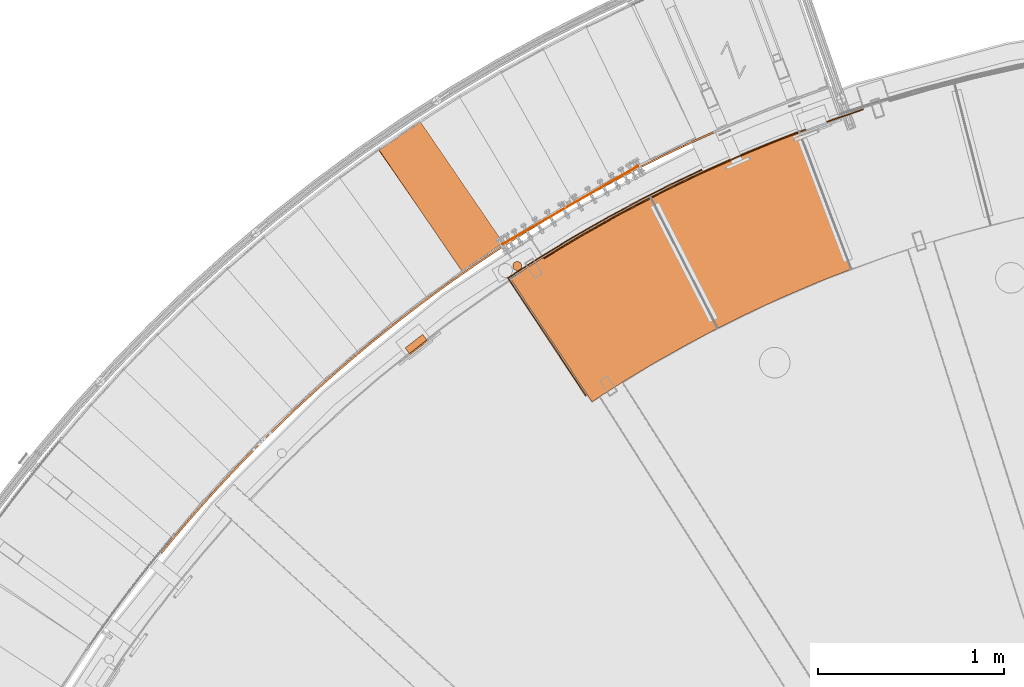
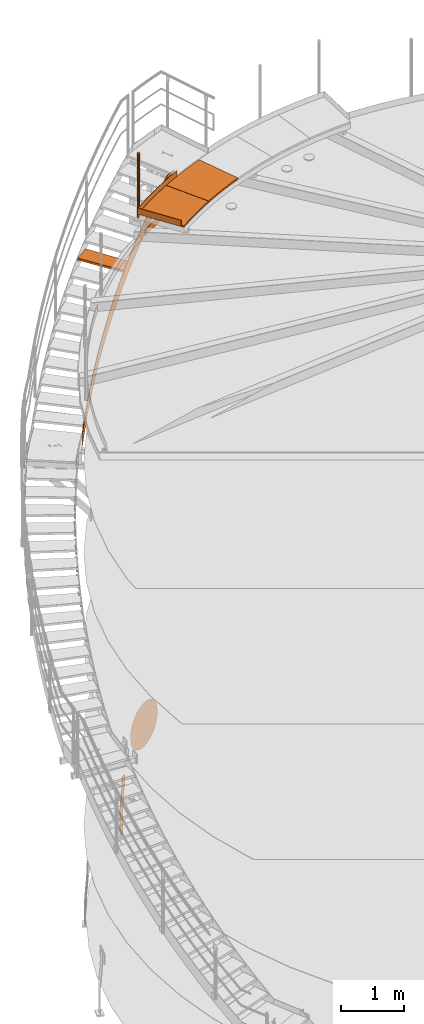
# One storey, part 36 of 126: 10 proxies.
"""IFC2X3 building model written with IfcOpenShell, lengths in millimetres."""

from ifc_helpers import new_model, si_unit, origin, origin_with_axes, place, context, project, spatial, faceted_brep, material, element, save


model = new_model("IFC2X3")

# Units and contexts
context_of_model_1 = context(None, 3, precision=0.1, world=origin())
context_of_model_2 = context(None, 3, precision=0.1, world=origin())
ifc_project = project(units=[si_unit("LENGTHUNIT", "METRE", prefix="MILLI"), si_unit("AREAUNIT", "SQUARE_METRE", prefix="CENTI"), si_unit("VOLUMEUNIT", "CUBIC_METRE", prefix="CENTI"), si_unit("MASSUNIT", "GRAM", prefix="KILO")], contexts=[context_of_model_1, context_of_model_2])

# Site, building, storey
site_placement = place(None, origin_with_axes())
site = spatial("IfcSite", under=ifc_project, at=site_placement, CompositionType="ELEMENT")
building_placement = place(site_placement, origin_with_axes())
building = spatial("IfcBuilding", under=site, at=building_placement, CompositionType="ELEMENT")
storey_placement = place(building_placement, origin_with_axes())
storey = spatial("IfcBuildingStorey", under=building, at=storey_placement, CompositionType="ELEMENT")

# Proxies
ifc_material_1 = material(Name="STAHL")
proxy_1_placement = place(storey_placement, origin_with_axes())
element("IfcBuildingElementProxy", 1, at=proxy_1_placement, inside=storey, material=ifc_material_1, Name="profile", context=context_of_model_2, shape_type="Brep", body=[
    faceted_brep([(3653.7, 14739.6, 896.0), (3655.8, 14740.8, 852.6), (3661.8, 14744.3, 809.8), (3671.9, 14750.1, 768.0), (3685.8, 14758.2, 727.6), (3703.4, 14768.3, 689.3), (3724.5, 14780.5, 653.3), (3748.9, 14794.6, 620.2), (3776.2, 14810.3, 590.4), (3774.7, 14812.9, 590.4), (3747.4, 14797.2, 620.2), (3723.0, 14783.1, 653.3), (3701.9, 14770.9, 689.3), (3684.3, 14760.8, 727.6), (3670.4, 14752.7, 768.0), (3660.3, 14746.9, 809.8), (3654.3, 14743.4, 852.6), (3652.2, 14742.2, 896.0), (3654.3, 14743.4, 939.4), (3660.3, 14746.9, 982.2), (3670.4, 14752.7, 1024.0), (3684.3, 14760.8, 1064.4), (3701.9, 14770.9, 1102.7), (3723.0, 14783.1, 1138.7), (3747.4, 14797.2, 1171.8), (3774.7, 14812.9, 1201.6), (3804.6, 14830.2, 1227.9), (3836.8, 14848.8, 1250.3), (3871.0, 14868.5, 1268.5), (3906.6, 14889.1, 1282.4), (3943.3, 14910.3, 1291.7), (3980.7, 14931.9, 1296.4), (4018.3, 14953.6, 1296.4), (4055.7, 14975.2, 1291.7), (4092.4, 14996.4, 1282.4), (4128.0, 15016.9, 1268.5), (4162.2, 15036.6, 1250.3), (4194.4, 15055.2, 1227.9), (4224.3, 15072.5, 1201.6), (4251.6, 15088.3, 1171.8), (4276.0, 15102.3, 1138.7), (4297.1, 15114.5, 1102.7), (4314.7, 15124.7, 1064.4), (4328.6, 15132.7, 1024.0), (4338.7, 15138.5, 982.2), (4344.7, 15142.1, 939.4), (4346.8, 15143.2, 896.0), (4344.7, 15142.1, 852.6), (4338.7, 15138.5, 809.8), (4328.6, 15132.7, 768.0), (4314.7, 15124.7, 727.6), (4297.1, 15114.5, 689.3), (4276.0, 15102.3, 653.3), (4251.6, 15088.3, 620.2), (4224.3, 15072.5, 590.4), (4194.4, 15055.2, 564.1), (4162.2, 15036.6, 541.7), (4128.0, 15016.9, 523.5), (4092.4, 14996.4, 509.6), (4055.7, 14975.2, 500.3), (4018.3, 14953.6, 495.6), (3980.7, 14931.9, 495.6), (3943.3, 14910.3, 500.3), (3906.6, 14889.1, 509.6), (3871.0, 14868.5, 523.5), (3836.8, 14848.8, 541.7), (3804.6, 14830.2, 564.1), (3806.1, 14827.6, 564.1), (3838.3, 14846.2, 541.7), (3872.5, 14865.9, 523.5), (3908.1, 14886.5, 509.6), (3944.8, 14907.7, 500.3), (3982.2, 14929.3, 495.6), (4019.8, 14951.0, 495.6), (4057.2, 14972.6, 500.3), (4093.9, 14993.8, 509.6), (4129.5, 15014.3, 523.5), (4163.7, 15034.0, 541.7), (4195.9, 15052.6, 564.1), (4225.8, 15069.9, 590.4), (4253.1, 15085.7, 620.2), (4277.5, 15099.7, 653.3), (4298.6, 15111.9, 689.3), (4316.2, 15122.1, 727.6), (4330.1, 15130.1, 768.0), (4340.2, 15135.9, 809.8), (4346.2, 15139.5, 852.6), (4348.3, 15140.6, 896.0), (4346.2, 15139.5, 939.4), (4340.2, 15135.9, 982.2), (4330.1, 15130.1, 1024.0), (4316.2, 15122.1, 1064.4), (4298.6, 15111.9, 1102.7), (4277.5, 15099.7, 1138.7), (4253.1, 15085.7, 1171.8), (4225.8, 15069.9, 1201.6), (4195.9, 15052.6, 1227.9), (4163.7, 15034.0, 1250.3), (4129.5, 15014.3, 1268.5), (4093.9, 14993.8, 1282.4), (4057.2, 14972.6, 1291.7), (4019.8, 14951.0, 1296.4), (3982.2, 14929.3, 1296.4), (3944.8, 14907.7, 1291.7), (3908.1, 14886.5, 1282.4), (3872.5, 14865.9, 1268.5), (3838.3, 14846.2, 1250.3), (3806.1, 14827.6, 1227.9), (3776.2, 14810.3, 1201.6), (3748.9, 14794.6, 1171.8), (3724.5, 14780.5, 1138.7), (3703.4, 14768.3, 1102.7), (3685.8, 14758.2, 1064.4), (3671.9, 14750.1, 1024.0), (3661.8, 14744.3, 982.2), (3655.8, 14740.8, 939.4), (3636.4, 14729.6, 896.0), (3638.4, 14730.8, 940.0), (3644.4, 14734.2, 983.5), (3654.2, 14739.9, 1026.1), (3667.9, 14747.8, 1067.2), (3685.2, 14757.8, 1106.5), (3706.0, 14769.8, 1143.5), (3730.1, 14783.7, 1177.7), (3757.0, 14799.3, 1208.9), (3786.7, 14816.4, 1236.6), (3818.7, 14834.9, 1260.6), (3852.7, 14854.5, 1280.6), (3888.3, 14875.1, 1296.4), (3925.2, 14896.4, 1307.8), (3962.9, 14918.1, 1314.7), (4001.0, 14940.1, 1317.0), (4039.1, 14962.1, 1314.7), (4076.8, 14983.9, 1307.8), (4113.7, 15005.2, 1296.4), (4149.3, 15025.7, 1280.6), (4183.3, 15045.4, 1260.6), (4213.8, 15066.5, 1236.6), (4181.8, 15048.0, 1260.6), (4147.8, 15028.3, 1280.6), (4112.2, 15007.8, 1296.4), (4075.3, 14986.5, 1307.8), (4037.6, 14964.7, 1314.7), (3999.5, 14942.7, 1317.0), (3961.4, 14920.7, 1314.7), (3923.7, 14899.0, 1307.8), (3886.8, 14877.7, 1296.4), (3851.2, 14857.1, 1280.6), (3817.2, 14837.5, 1260.6), (3785.2, 14819.0, 1236.6), (3755.5, 14801.9, 1208.9), (3728.6, 14786.3, 1177.7), (3704.5, 14772.4, 1143.5), (3683.7, 14760.4, 1106.5), (3666.4, 14750.4, 1067.2), (3652.7, 14742.5, 1026.1), (3642.9, 14736.8, 983.5), (3636.9, 14733.4, 940.0), (3634.9, 14732.2, 896.0), (3636.9, 14733.4, 852.0), (3642.9, 14736.8, 808.5), (3652.7, 14742.5, 765.9), (3666.4, 14750.4, 724.8), (3683.7, 14760.4, 685.5), (3704.5, 14772.4, 648.5), (3728.6, 14786.3, 614.3), (3755.5, 14801.9, 583.1), (3785.2, 14819.0, 555.4), (3817.2, 14837.5, 531.4), (3851.2, 14857.1, 511.4), (3886.8, 14877.7, 495.6), (3923.7, 14899.0, 484.2), (3961.4, 14920.7, 477.3), (3999.5, 14942.7, 475.0), (4037.6, 14964.7, 477.3), (4075.3, 14986.5, 484.2), (4112.2, 15007.8, 495.6), (4147.8, 15028.3, 511.4), (4181.8, 15048.0, 531.4), (4213.8, 15066.5, 555.4), (4243.5, 15083.6, 583.1), (4270.4, 15099.2, 614.3), (4294.5, 15113.0, 648.5), (4315.2, 15125.0, 685.5), (4332.6, 15135.0, 724.8), (4346.3, 15142.9, 765.9), (4356.1, 15148.6, 808.5), (4362.1, 15152.1, 852.0), (4364.1, 15153.2, 896.0), (4362.1, 15152.1, 940.0), (4356.1, 15148.6, 983.5), (4346.3, 15142.9, 1026.1), (4332.6, 15135.0, 1067.2), (4315.2, 15125.0, 1106.5), (4294.5, 15113.0, 1143.5), (4270.4, 15099.2, 1177.7), (4243.5, 15083.6, 1208.9), (4215.3, 15063.9, 1236.6), (4245.0, 15081.0, 1208.9), (4271.9, 15096.6, 1177.7), (4296.0, 15110.4, 1143.5), (4316.7, 15122.4, 1106.5), (4334.1, 15132.4, 1067.2), (4347.8, 15140.3, 1026.1), (4357.6, 15146.0, 983.5), (4363.6, 15149.5, 940.0), (4365.6, 15150.6, 896.0), (4363.6, 15149.5, 852.0), (4357.6, 15146.0, 808.5), (4347.8, 15140.3, 765.9), (4334.1, 15132.4, 724.8), (4316.7, 15122.4, 685.5), (4296.0, 15110.4, 648.5), (4271.9, 15096.6, 614.3), (4245.0, 15081.0, 583.1), (4215.3, 15063.9, 555.4), (4183.3, 15045.4, 531.4), (4149.3, 15025.7, 511.4), (4113.7, 15005.2, 495.6), (4076.8, 14983.9, 484.2), (4039.1, 14962.1, 477.3), (4001.0, 14940.1, 475.0), (3962.9, 14918.1, 477.3), (3925.2, 14896.4, 484.2), (3888.3, 14875.1, 495.6), (3852.7, 14854.5, 511.4), (3818.7, 14834.9, 531.4), (3786.7, 14816.4, 555.4), (3757.0, 14799.3, 583.1), (3730.1, 14783.7, 614.3), (3706.0, 14769.8, 648.5), (3685.2, 14757.8, 685.5), (3667.9, 14747.8, 724.8), (3654.2, 14739.9, 765.9), (3644.4, 14734.2, 808.5), (3638.4, 14730.8, 852.0)], [[[0, 1, 2, 3, 4, 5, 6, 7, 8, 9, 10, 11, 12, 13, 14, 15, 16, 17, 18, 19, 20, 21, 22, 23, 24, 25, 26, 27, 28, 29, 30, 31, 32, 33, 34, 35, 36, 37, 38, 39, 40, 41, 42, 43, 44, 45, 46, 47, 48, 49, 50, 51, 52, 53, 54, 55, 56, 57, 58, 59, 60, 61, 62, 63, 64, 65, 66, 9, 8, 67, 68, 69, 70, 71, 72, 73, 74, 75, 76, 77, 78, 79, 80, 81, 82, 83, 84, 85, 86, 87, 88, 89, 90, 91, 92, 93, 94, 95, 96, 97, 98, 99, 100, 101, 102, 103, 104, 105, 106, 107, 108, 109, 110, 111, 112, 113, 114, 115]], [[116, 117, 118, 119, 120, 121, 122, 123, 124, 125, 126, 127, 128, 129, 130, 131, 132, 133, 134, 135, 136, 137, 138, 139, 140, 141, 142, 143, 144, 145, 146, 147, 148, 149, 150, 151, 152, 153, 154, 155, 156, 157, 158, 159, 160, 161, 162, 163, 164, 165, 166, 167, 168, 169, 170, 171, 172, 173, 174, 175, 176, 177, 178, 179, 180, 181, 182, 183, 184, 185, 186, 187, 188, 189, 190, 191, 192, 193, 194, 195, 196, 137, 136, 197, 198, 199, 200, 201, 202, 203, 204, 205, 206, 207, 208, 209, 210, 211, 212, 213, 214, 215, 216, 217, 218, 219, 220, 221, 222, 223, 224, 225, 226, 227, 228, 229, 230, 231, 232, 233, 234, 235]], [[158, 157, 156, 155, 154, 153, 152, 151, 150, 149, 148, 147, 146, 145, 144, 143, 142, 141, 140, 139, 138, 137, 196, 195, 194, 193, 192, 191, 190, 189, 188, 187, 186, 185, 184, 183, 182, 181, 180, 53, 52, 51, 50, 49, 48, 47, 46, 45, 44, 43, 42, 41, 40, 39, 38, 37, 36, 35, 34, 33, 32, 31, 30, 29, 28, 27, 26, 25, 24, 23, 22, 21, 20, 19, 18, 17, 16, 15, 14, 13, 12, 11, 10, 9, 66, 65, 64, 63, 62, 61, 60, 59, 58, 57, 56, 55, 54, 53, 180, 179, 178, 177, 176, 175, 174, 173, 172, 171, 170, 169, 168, 167, 166, 165, 164, 163, 162, 161, 160, 159]], [[116, 235, 234, 233, 232, 231, 230, 229, 228, 227, 226, 225, 224, 223, 222, 221, 220, 219, 218, 217, 216, 215, 214, 213, 80, 79, 78, 77, 76, 75, 74, 73, 72, 71, 70, 69, 68, 67, 8, 7, 6, 5, 4, 3, 2, 1, 0, 115, 114, 113, 112, 111, 110, 109, 108, 107, 106, 105, 104, 103, 102, 101, 100, 99, 98, 97, 96, 95, 94, 93, 92, 91, 90, 89, 88, 87, 86, 85, 84, 83, 82, 81, 80, 213, 212, 211, 210, 209, 208, 207, 206, 205, 204, 203, 202, 201, 200, 199, 198, 197, 136, 135, 134, 133, 132, 131, 130, 129, 128, 127, 126, 125, 124, 123, 122, 121, 120, 119, 118, 117]]]),
])
proxy_2_placement = place(storey_placement, origin_with_axes())
element("IfcBuildingElementProxy", 2, at=proxy_2_placement, inside=storey, material=ifc_material_1, Name="profile", context=context_of_model_2, shape_type="Brep", body=[
    faceted_brep([(3224.1, 14212.2, 654.1), (3229.0, 14205.9, 654.1), (3231.0, 14207.5, 651.1), (3226.0, 14213.8, 651.1), (3227.5, 14214.9, 647.7), (3232.4, 14208.6, 647.7), (3228.4, 14215.6, 643.9), (3233.3, 14209.3, 643.9), (3233.6, 14209.5, 640.0), (3233.6, 14209.5, 540.0), (3210.2, 14239.5, 0.0), (3210.2, 14239.5, -500.0), (3205.3, 14245.8, -500.0), (3205.3, 14245.8, 0.0), (3228.7, 14215.8, 540.0), (3228.7, 14215.8, 640.0), (3143.7, 14139.3, 654.1), (3138.8, 14145.6, 654.1), (3136.8, 14144.0, 651.1), (3141.7, 14137.7, 651.1), (3135.3, 14142.9, 647.7), (3140.3, 14136.6, 647.7), (3134.4, 14142.2, 643.9), (3139.4, 14135.9, 643.9), (3139.1, 14135.7, 540.0), (3139.1, 14135.7, 640.0), (3134.1, 14142.0, 640.0), (3134.1, 14142.0, 540.0), (3110.7, 14171.9, 0.0), (3110.7, 14171.9, -500.0), (3115.7, 14165.6, -500.0), (3115.7, 14165.6, 0.0), (3151.8, 14145.6, 659.6), (3154.8, 14148.0, 660.0), (3217.9, 14197.2, 660.0), (3220.9, 14199.6, 659.6), (3216.0, 14205.9, 659.6), (3212.9, 14203.5, 660.0), (3149.9, 14154.3, 660.0), (3146.8, 14151.9, 659.6), (3143.9, 14149.6, 658.5), (3148.8, 14143.3, 658.5), (3141.1, 14147.4, 656.6), (3146.1, 14141.1, 656.6), (3223.9, 14201.9, 658.5), (3219.0, 14208.2, 658.5), (3226.6, 14204.1, 656.6), (3221.7, 14210.4, 656.6)], [[[0, 1, 2, 3]], [[4, 3, 2, 5]], [[6, 4, 5, 7]], [[7, 8, 9, 10, 11, 12, 13, 14, 15, 6]], [[16, 17, 18, 19]], [[19, 18, 20, 21]], [[21, 20, 22, 23]], [[24, 25, 23, 22, 26, 27, 28, 29, 30, 31]], [[32, 33, 34, 35, 36, 37, 38, 39]], [[32, 39, 40, 41]], [[41, 40, 42, 43]], [[16, 43, 42, 17]], [[36, 35, 44, 45]], [[45, 44, 46, 47]], [[0, 47, 46, 1]], [[27, 26, 22, 20, 18, 17, 42, 40, 39, 38, 37, 36, 45, 47, 0, 3, 4, 6, 15, 14, 13, 12, 29, 28]], [[25, 24, 31, 30, 11, 10, 9, 8, 7, 5, 2, 1, 46, 44, 35, 34, 33, 32, 41, 43, 16, 19, 21, 23]], [[30, 29, 12, 11]]]),
])
proxy_3_placement = place(storey_placement, origin_with_axes())
element("IfcBuildingElementProxy", 3, at=proxy_3_placement, inside=storey, material=ifc_material_1, Name="profile", context=context_of_model_2, shape_type="Brep", body=[
    faceted_brep([(3738.8, 14616.2, 12185.2), (3738.8, 14616.2, 10955.2), (3737.5, 14621.9, 10955.2), (3737.5, 14621.9, 12185.2), (3734.8, 14627.1, 10955.2), (3734.8, 14627.1, 12185.2), (3731.1, 14631.5, 10955.2), (3731.1, 14631.5, 12185.2), (3726.3, 14634.9, 10955.2), (3726.3, 14634.9, 12185.2), (3720.9, 14637.0, 10955.2), (3720.9, 14637.0, 12185.2), (3715.1, 14637.8, 10955.2), (3715.1, 14637.8, 12185.2), (3709.3, 14637.2, 10955.2), (3709.3, 14637.2, 12185.2), (3703.9, 14635.2, 10955.2), (3703.9, 14635.2, 12185.2), (3699.0, 14632.0, 10955.2), (3699.0, 14632.0, 12185.2), (3695.1, 14627.7, 10955.2), (3695.1, 14627.7, 12185.2), (3692.3, 14622.6, 10955.2), (3692.3, 14622.6, 12185.2), (3690.8, 14617.0, 10955.2), (3690.8, 14617.0, 12185.2), (3690.7, 14611.2, 12185.2), (3690.7, 14611.2, 10955.2), (3692.0, 14605.5, 10955.2), (3692.0, 14605.5, 12185.2), (3694.7, 14600.3, 12185.2), (3694.7, 14600.3, 10955.2), (3698.4, 14595.9, 12185.2), (3698.4, 14595.9, 10955.2), (3703.2, 14592.5, 12185.2), (3703.2, 14592.5, 10955.2), (3708.6, 14590.3, 12185.2), (3708.6, 14590.3, 10955.2), (3714.4, 14589.5, 12185.2), (3714.4, 14589.5, 10955.2), (3720.2, 14590.1, 12185.2), (3720.2, 14590.1, 10955.2), (3725.6, 14592.1, 12185.2), (3725.6, 14592.1, 10955.2), (3730.5, 14595.4, 12185.2), (3730.5, 14595.4, 10955.2), (3734.4, 14599.7, 12185.2), (3734.4, 14599.7, 10955.2), (3737.2, 14604.8, 12185.2), (3737.2, 14604.8, 10955.2), (3738.7, 14610.4, 12185.2), (3738.7, 14610.4, 10955.2)], [[[0, 1, 2, 3]], [[3, 2, 4, 5]], [[5, 4, 6, 7]], [[7, 6, 8, 9]], [[9, 8, 10, 11]], [[11, 10, 12, 13]], [[13, 12, 14, 15]], [[15, 14, 16, 17]], [[17, 16, 18, 19]], [[19, 18, 20, 21]], [[21, 20, 22, 23]], [[23, 22, 24, 25]], [[26, 25, 24, 27]], [[26, 27, 28, 29]], [[30, 29, 28, 31]], [[32, 30, 31, 33]], [[34, 32, 33, 35]], [[36, 34, 35, 37]], [[38, 36, 37, 39]], [[40, 38, 39, 41]], [[42, 40, 41, 43]], [[44, 42, 43, 45]], [[46, 44, 45, 47]], [[48, 46, 47, 49]], [[50, 48, 49, 51]], [[0, 50, 51, 1]], [[38, 40, 42, 44, 46, 48, 50, 0, 3, 5, 7, 9, 11, 13, 15, 17, 19, 21, 23, 25, 26, 29, 30, 32, 34, 36]], [[39, 37, 35, 33, 31, 28, 27, 24, 22, 20, 18, 16, 14, 12, 10, 8, 6, 4, 2, 1, 51, 49, 47, 45, 43, 41]]]),
])
proxy_4_placement = place(storey_placement, origin_with_axes())
element("IfcBuildingElementProxy", 4, at=proxy_4_placement, inside=storey, material=ifc_material_1, Name="profile", context=context_of_model_2, shape_type="Brep", body=[
    faceted_brep([(3661.2, 14549.6, 11065.2), (3661.2, 14549.6, 11185.2), (3665.4, 14552.4, 11185.2), (3835.8, 14662.2, 11185.2), (4009.0, 14767.6, 11185.2), (4204.6, 14879.4, 11185.2), (4383.3, 14975.2, 11185.2), (4544.9, 15056.8, 11185.2), (4708.3, 15134.7, 11185.2), (4708.3, 15134.7, 11065.2), (4544.9, 15056.8, 11065.2), (4383.3, 14975.2, 11065.2), (4204.6, 14879.4, 11065.2), (4009.0, 14767.6, 11065.2), (3835.8, 14662.2, 11065.2), (3665.4, 14552.4, 11065.2), (3668.1, 14548.2, 11185.2), (3668.1, 14548.2, 11065.2), (3838.5, 14658.0, 11065.2), (4011.7, 14763.4, 11065.2), (4207.2, 14875.1, 11065.2), (4385.8, 14970.9, 11065.2), (4547.2, 15052.4, 11065.2), (4710.4, 15130.2, 11065.2), (4710.4, 15130.2, 11185.2), (4567.4, 15062.3, 11185.2), (4425.8, 14991.6, 11185.2), (4246.6, 14896.8, 11185.2), (4050.5, 14786.2, 11185.2), (3857.6, 14670.0, 11185.2), (3762.4, 14609.8, 11185.2), (4083.0, 13912.4, 11065.2), (4083.0, 13912.4, 11185.2), (4087.1, 13915.2, 11185.2), (4087.1, 13915.2, 11065.2)], [[[0, 1, 2, 3, 4, 5, 6, 7, 8, 9, 10, 11, 12, 13, 14, 15]], [[16, 17, 18, 19, 20, 21, 22, 23, 24, 25, 26, 27, 28, 29, 30]], [[9, 8, 24, 23]], [[1, 0, 31, 32]], [[32, 33, 16, 30, 29, 28, 27, 26, 25, 24, 8, 7, 6, 5, 4, 3, 2, 1]], [[31, 0, 15, 14, 13, 12, 11, 10, 9, 23, 22, 21, 20, 19, 18, 17, 34]], [[16, 33, 34, 17]], [[32, 31, 34, 33]]]),
])
proxy_5_placement = place(storey_placement, origin_with_axes())
element("IfcBuildingElementProxy", 5, at=proxy_5_placement, inside=storey, material=ifc_material_1, Name="profile", context=context_of_model_2, shape_type="Brep", body=[
    faceted_brep([(3856.5, 14657.3, 10516.0), (3856.5, 14657.3, 10636.0), (4060.3, 14780.1, 10636.0), (4267.7, 14896.7, 10636.0), (4478.5, 15007.0, 10636.0), (4692.6, 15110.7, 10636.0), (4909.8, 15208.0, 10636.0), (5129.8, 15298.6, 10636.0), (5352.4, 15382.5, 10636.0), (5577.5, 15459.6, 10636.0), (5577.5, 15459.6, 10516.0), (5352.4, 15382.5, 10516.0), (5129.8, 15298.6, 10516.0), (4909.8, 15208.0, 10516.0), (4692.6, 15110.7, 10516.0), (4478.5, 15007.0, 10516.0), (4267.7, 14896.7, 10516.0), (4060.3, 14780.1, 10516.0), (3859.2, 14653.1, 10636.0), (4062.8, 14775.8, 10636.0), (4270.1, 14892.3, 10636.0), (4480.8, 15002.5, 10636.0), (4694.7, 15106.2, 10636.0), (4911.8, 15203.4, 10636.0), (5131.6, 15293.9, 10636.0), (5354.1, 15377.8, 10636.0), (5579.0, 15454.8, 10636.0), (3859.2, 14653.1, 10516.0), (4062.8, 14775.8, 10516.0), (4270.1, 14892.3, 10516.0), (4480.8, 15002.5, 10516.0), (4694.7, 15106.2, 10516.0), (4911.8, 15203.4, 10516.0), (5131.6, 15293.9, 10516.0), (5354.1, 15377.8, 10516.0), (5579.0, 15454.8, 10516.0)], [[[0, 1, 2, 3, 4, 5, 6, 7, 8, 9, 10, 11, 12, 13, 14, 15, 16, 17]], [[18, 19, 20, 21, 22, 23, 24, 25, 26, 9, 8, 7, 6, 5, 4, 3, 2, 1]], [[18, 27, 28, 29, 30, 31, 32, 33, 34, 35, 26, 25, 24, 23, 22, 21, 20, 19]], [[27, 0, 17, 16, 15, 14, 13, 12, 11, 10, 35, 34, 33, 32, 31, 30, 29, 28]], [[18, 1, 0, 27]], [[26, 35, 10, 9]]]),
])
proxy_6_placement = place(storey_placement, origin_with_axes())
element("IfcBuildingElementProxy", 6, at=proxy_6_placement, inside=storey, material=ifc_material_1, Name="profile", context=context_of_model_2, shape_type="Brep", body=[
    faceted_brep([(4796.6, 14279.2, 11085.2), (4796.6, 14279.2, 11055.2), (4972.1, 14365.9, 11055.2), (5150.0, 14447.7, 11055.2), (5330.0, 14524.6, 11055.2), (5512.2, 14596.4, 11055.2), (5512.2, 14596.4, 11085.2), (5330.0, 14524.6, 11085.2), (5150.0, 14447.7, 11085.2), (4972.1, 14365.9, 11085.2), (4433.9, 14987.8, 11085.2), (4433.9, 14987.8, 11055.2), (4590.1, 15065.5, 11085.2), (4747.9, 15139.7, 11085.2), (4907.4, 15210.4, 11085.2), (5068.4, 15277.5, 11085.2), (5230.8, 15341.0, 11085.2), (5230.8, 15341.0, 11055.2), (5068.4, 15277.5, 11055.2), (4907.4, 15210.4, 11055.2), (4747.9, 15139.7, 11055.2), (4590.1, 15065.5, 11055.2)], [[[0, 1, 2, 3, 4, 5, 6, 7, 8, 9]], [[0, 10, 11, 1]], [[11, 10, 12, 13, 14, 15, 16, 17, 18, 19, 20, 21]], [[16, 6, 5, 17]], [[0, 9, 8, 7, 6, 16, 15, 14, 13, 12, 10]], [[1, 11, 21, 20, 19, 18, 17, 5, 4, 3, 2]]]),
])
proxy_7_placement = place(storey_placement, origin_with_axes())
element("IfcBuildingElementProxy", 7, at=proxy_7_placement, inside=storey, material=ifc_material_1, Name="profile", context=context_of_model_2, shape_type="Brep", body=[
    faceted_brep([(4117.2, 13882.5, 11085.2), (4117.2, 13882.5, 11055.2), (4281.9, 13988.2, 11055.2), (4449.6, 14089.3, 11055.2), (4620.0, 14185.8, 11055.2), (4793.0, 14277.4, 11055.2), (4793.0, 14277.4, 11085.2), (4620.0, 14185.8, 11085.2), (4449.6, 14089.3, 11085.2), (4281.9, 13988.2, 11085.2), (3677.8, 14546.3, 11085.2), (3677.8, 14546.3, 11055.2), (3861.3, 14664.0, 11085.2), (4048.0, 14776.6, 11085.2), (4237.7, 14884.0, 11085.2), (4430.4, 14986.0, 11085.2), (4430.4, 14986.0, 11055.2), (4237.7, 14884.0, 11055.2), (4048.0, 14776.6, 11055.2), (3861.3, 14664.0, 11055.2)], [[[0, 1, 2, 3, 4, 5, 6, 7, 8, 9]], [[0, 10, 11, 1]], [[11, 10, 12, 13, 14, 15, 16, 17, 18, 19]], [[15, 6, 5, 16]], [[0, 9, 8, 7, 6, 15, 14, 13, 12, 10]], [[1, 11, 19, 18, 17, 16, 5, 4, 3, 2]]]),
])
ifc_material_2 = material(Name="HOLZ")
proxy_8_placement = place(storey_placement, origin_with_axes())
element("IfcBuildingElementProxy", 8, at=proxy_8_placement, inside=storey, material=ifc_material_2, context=context_of_model_2, shape_type="Brep", body=[
    faceted_brep([(3205.7057, 15401.368, 10045.963), (3183.6454, 15387.007, 10045.963), (3161.628, 15372.58, 10045.963), (3139.6538, 15358.087, 10045.963), (3117.723, 15343.529, 10045.963), (3095.8357, 15328.906, 10045.963), (3073.9922, 15314.217, 10045.963), (3052.1926, 15299.463, 10045.963), (3030.4372, 15284.644, 10045.963), (3008.7261, 15269.76, 10045.963), (2987.0595, 15254.811, 10045.963), (2965.4377, 15239.798, 10045.963), (3422.6964, 14583.357, 10045.963), (3444.5485, 14598.525, 10045.963), (3466.4508, 14613.62, 10045.963), (3488.4031, 14628.643, 10045.963), (3510.4051, 14643.592, 10045.963), (3532.4566, 14658.469, 10045.963), (3554.5573, 14673.272, 10045.963), (3576.707, 14688.002, 10045.963), (3598.9055, 14702.658, 10045.963), (3621.1525, 14717.24, 10045.963), (3643.4477, 14731.749, 10045.963), (3205.7057, 15401.368, 10005.963), (3643.4477, 14731.749, 10005.963), (3621.1525, 14717.24, 10005.963), (3598.9055, 14702.658, 10005.963), (3576.707, 14688.002, 10005.963), (3554.5573, 14673.272, 10005.963), (3532.4566, 14658.469, 10005.963), (3510.4051, 14643.592, 10005.963), (3488.4031, 14628.643, 10005.963), (3466.4508, 14613.62, 10005.963), (3444.5485, 14598.525, 10005.963), (3422.6964, 14583.357, 10005.963), (2965.4377, 15239.798, 10005.963), (2987.0595, 15254.811, 10005.963), (3008.7261, 15269.76, 10005.963), (3030.4372, 15284.644, 10005.963), (3052.1926, 15299.463, 10005.963), (3073.9922, 15314.217, 10005.963), (3095.8357, 15328.906, 10005.963), (3117.723, 15343.529, 10005.963), (3139.6538, 15358.087, 10005.963), (3161.628, 15372.58, 10005.963), (3183.6454, 15387.007, 10005.963)], [[[0, 1, 2, 3, 4, 5, 6, 7, 8, 9, 10, 11, 12, 13, 14, 15, 16, 17, 18, 19, 20, 21, 22]], [[23, 24, 25, 26, 27, 28, 29, 30, 31, 32, 33, 34, 35, 36, 37, 38, 39, 40, 41, 42, 43, 44, 45]], [[0, 23, 45, 1]], [[1, 45, 44, 2]], [[2, 44, 43, 3]], [[3, 43, 42, 4]], [[4, 42, 41, 5]], [[5, 41, 40, 6]], [[6, 40, 39, 7]], [[7, 39, 38, 8]], [[8, 38, 37, 9]], [[9, 37, 36, 10]], [[10, 36, 35, 11]], [[11, 35, 34, 12]], [[12, 34, 33, 13]], [[13, 33, 32, 14]], [[14, 32, 31, 15]], [[15, 31, 30, 16]], [[16, 30, 29, 17]], [[17, 29, 28, 18]], [[18, 28, 27, 19]], [[19, 27, 26, 20]], [[20, 26, 25, 21]], [[21, 25, 24, 22]], [[22, 24, 23, 0]]]),
])
ifc_material_3 = material(Name="S235JRG2")
proxy_9_placement = place(storey_placement, origin_with_axes())
element("IfcBuildingElementProxy", 9, at=proxy_9_placement, inside=storey, material=ifc_material_3, context=context_of_model_2, shape_type="Brep", body=[
    faceted_brep([(2971.1265, 15237.649, 10005.55), (2971.1265, 15237.649, 10045.55), (3194.0134, 15390.035, 10045.55), (3194.0134, 15390.035, 10005.55), (3416.996, 14585.498, 10005.55), (3639.8829, 14737.884, 10005.55), (3639.8829, 14737.884, 10045.55), (3416.996, 14585.498, 10045.55)], [[[0, 1, 2, 3]], [[4, 5, 6, 7]], [[0, 4, 7, 1]], [[1, 7, 6, 2]], [[2, 6, 5, 3]], [[3, 5, 4, 0]]]),
])
proxy_10_placement = place(storey_placement, origin_with_axes())
element("IfcBuildingElementProxy", 10, at=proxy_10_placement, inside=storey, material=ifc_material_3, context=context_of_model_2, shape_type="Brep", body=[
    faceted_brep([(1801.9537, 13080.672, 8172.7859), (1809.6931, 13074.339, 8172.7017), (1802.471, 13065.417, 8164.2676), (1794.2032, 13071.097, 8163.7395), (1809.6931, 13074.339, 8420.8838), (1802.471, 13065.417, 8412.4466), (1801.9537, 13080.672, 8420.9227), (1794.2032, 13071.097, 8411.8796), (1856.0518, 13146.076, 8235.1084), (1863.7237, 13139.662, 8234.9977), (1863.7237, 13139.662, 8483.193), (1856.0518, 13146.076, 8483.2319), (1910.8395, 13210.904, 8297.4253), (1918.443, 13204.408, 8297.2993), (1918.443, 13204.408, 8545.5023), (1910.8395, 13210.904, 8545.5412), (1966.3106, 13275.148, 8359.739), (1973.8449, 13268.572, 8359.6041), (1973.8449, 13268.572, 8607.8115), (1966.3106, 13275.148, 8607.8504), (2022.4589, 13338.8, 8422.0509), (2029.9232, 13332.146, 8421.9107), (2029.9232, 13332.146, 8670.1208), (2022.4589, 13338.8, 8670.1597), (2079.2782, 13401.855, 8484.3616), (2086.6716, 13395.122, 8484.2184), (2086.6716, 13395.122, 8732.43), (2079.2782, 13401.855, 8732.4689), (2136.762, 13464.305, 8546.6718), (2144.0836, 13457.493, 8546.5268), (2144.0836, 13457.493, 8794.7393), (2136.762, 13464.305, 8794.7782), (2194.9039, 13526.142, 8608.9815), (2202.153, 13519.253, 8608.8355), (2202.153, 13519.253, 8857.0485), (2194.9039, 13526.142, 8857.0874), (2253.6974, 13587.36, 8671.2911), (2260.8731, 13580.395, 8671.1444), (2260.8731, 13580.395, 8919.3578), (2253.6974, 13587.36, 8919.3967), (2313.1359, 13647.952, 8733.6005), (2320.2375, 13640.911, 8733.4535), (2320.2375, 13640.911, 8981.667), (2313.1359, 13647.952, 8981.7059), (2373.2127, 13707.911, 8795.9099), (2380.2393, 13700.796, 8795.7627), (2380.2393, 13700.796, 9043.9763), (2373.2127, 13707.911, 9044.0152), (2433.921, 13767.231, 8858.2192), (2440.872, 13760.041, 8858.0719), (2440.872, 13760.041, 9106.2855), (2433.921, 13767.231, 9106.3244), (2495.2542, 13825.904, 8920.5284), (2502.1286, 13818.642, 8920.3811), (2502.1286, 13818.642, 9168.5948), (2495.2542, 13825.904, 9168.6336), (2557.2053, 13883.925, 8982.8377), (2564.0024, 13876.59, 8982.6903), (2564.0024, 13876.59, 9230.904), (2557.2053, 13883.925, 9230.9429), (2619.7673, 13941.286, 9045.147), (2626.4863, 13933.88, 9044.9995), (2626.4863, 13933.88, 9293.2132), (2619.7673, 13941.286, 9293.2521), (2682.9332, 13997.982, 9107.4562), (2689.5735, 13990.504, 9107.3088), (2689.5735, 13990.504, 9355.5225), (2682.9332, 13997.982, 9355.5614), (2746.696, 14054.005, 9169.7655), (2753.2567, 14046.458, 9169.618), (2753.2567, 14046.458, 9417.8317), (2746.696, 14054.005, 9417.8706), (2811.0485, 14109.35, 9232.0747), (2817.5289, 14101.734, 9231.9273), (2817.5289, 14101.734, 9480.141), (2811.0485, 14109.35, 9480.1799), (2875.9835, 14164.011, 9294.384), (2882.3829, 14156.326, 9294.2365), (2882.3829, 14156.326, 9542.4502), (2875.9835, 14164.011, 9542.4891), (2941.4937, 14217.981, 9356.6932), (2947.8113, 14210.229, 9356.5458), (2947.8113, 14210.229, 9604.7595), (2941.4937, 14217.981, 9604.7984), (3007.5718, 14271.254, 9419.0025), (3013.8069, 14263.435, 9418.855), (3013.8069, 14263.435, 9667.0687), (3007.5718, 14271.254, 9667.1076), (3074.2102, 14323.824, 9481.3117), (3080.3623, 14315.94, 9481.1642), (3080.3623, 14315.94, 9729.378), (3074.2102, 14323.824, 9729.4169), (3141.4017, 14375.686, 9543.621), (3147.4699, 14367.737, 9543.4735), (3147.4699, 14367.737, 9791.6872), (3141.4017, 14375.686, 9791.7261), (3209.1386, 14426.833, 9605.9302), (3215.1223, 14418.821, 9605.7827), (3215.1223, 14418.821, 9853.9965), (3209.1386, 14426.833, 9854.0354), (3277.4133, 14477.26, 9668.2395), (3283.3118, 14469.185, 9668.092), (3283.3118, 14469.185, 9916.3057), (3277.4133, 14477.26, 9916.3446), (3346.2183, 14526.961, 9730.5487), (3352.0309, 14518.824, 9730.4012), (3352.0309, 14518.824, 9978.615), (3346.2183, 14526.961, 9978.6539), (3415.5456, 14575.931, 9792.858), (3421.2718, 14567.733, 9792.7105), (3421.2718, 14567.733, 10040.924), (3415.5456, 14575.931, 10040.963), (3485.3877, 14624.164, 9855.1672), (3491.0267, 14615.905, 9855.0197), (3491.0267, 14615.905, 10103.234), (3485.3877, 14624.164, 10103.272), (3555.7366, 14671.654, 9917.4765), (3561.2879, 14663.336, 9917.329), (3561.2879, 14663.336, 10165.543), (3555.7366, 14671.654, 10165.582), (3626.5845, 14718.397, 9979.7857), (3632.0474, 14710.021, 9979.6382), (3632.0474, 14710.021, 10227.852), (3626.5845, 14718.397, 10227.891), (3697.9235, 14764.387, 10042.095), (3703.2973, 14755.954, 10041.948), (3703.2973, 14755.954, 10290.161), (3697.9235, 14764.387, 10290.2), (3769.7454, 14809.619, 10104.404), (3775.0297, 14801.129, 10104.257), (3775.0297, 14801.129, 10352.47), (3769.7454, 14809.619, 10352.509), (3842.0424, 14854.088, 10166.713), (3847.2364, 14845.543, 10166.566), (3847.2364, 14845.543, 10414.78), (3842.0424, 14854.088, 10414.819), (3914.8061, 14897.789, 10229.023), (3919.9094, 14889.189, 10228.875), (3919.9094, 14889.189, 10477.089), (3914.8061, 14897.789, 10477.128), (3988.0286, 14940.717, 10291.332), (3993.0405, 14932.063, 10291.184), (3993.0405, 14932.063, 10539.398), (3988.0286, 14940.717, 10539.437), (4061.7016, 14982.867, 10353.641), (4066.6216, 14974.161, 10353.494), (4066.6216, 14974.161, 10601.708), (4061.7016, 14982.867, 10601.746), (4135.8168, 15024.234, 10415.95), (4140.6443, 15015.476, 10415.803), (4140.6443, 15015.476, 10664.017), (4135.8168, 15024.234, 10664.056), (4210.3659, 15064.814, 10478.26), (4215.1004, 15056.006, 10478.112), (4215.1004, 15056.006, 10726.326), (4210.3659, 15064.814, 10726.365), (4285.3406, 15104.603, 10540.569), (4289.9815, 15095.745, 10540.422), (4289.9815, 15095.745, 10788.635), (4285.3406, 15104.603, 10788.674), (4360.7324, 15143.595, 10602.878), (4365.2793, 15134.688, 10602.731), (4365.2793, 15134.688, 10850.944), (4360.7324, 15143.595, 10850.983), (4436.5329, 15181.787, 10665.187), (4440.9852, 15172.832, 10665.04), (4440.9852, 15172.832, 10913.254), (4436.5329, 15181.787, 10913.293), (4512.7336, 15219.174, 10727.497), (4517.0908, 15210.173, 10727.349), (4517.0908, 15210.173, 10975.563), (4512.7336, 15219.174, 10975.602), (4589.326, 15255.752, 10789.806), (4593.5876, 15246.705, 10789.658), (4593.5876, 15246.705, 11037.872), (4589.326, 15255.752, 11037.911), (4666.3014, 15291.516, 10852.115), (4670.467, 15282.425, 10851.968), (4670.467, 15282.425, 11055.15), (4614.9056, 15256.61, 11055.15), (4610.6225, 15265.646, 11055.15), (4666.3014, 15291.516, 11055.15), (4743.6512, 15326.464, 10914.424), (4747.7203, 15317.329, 10914.277), (4747.7203, 15317.329, 11055.15), (4743.6512, 15326.464, 11055.15), (4769.642, 15337.877, 10935.263), (4773.8276, 15328.793, 10935.235), (4773.8276, 15328.793, 11055.15), (4769.642, 15337.877, 11055.15)], [[[0, 1, 2, 3]], [[1, 4, 5, 2]], [[4, 6, 7, 5]], [[0, 3, 7, 6]], [[0, 8, 9, 1]], [[1, 9, 10, 4]], [[4, 10, 11, 6]], [[6, 11, 8, 0]], [[8, 12, 13, 9]], [[9, 13, 14, 10]], [[10, 14, 15, 11]], [[11, 15, 12, 8]], [[12, 16, 17, 13]], [[13, 17, 18, 14]], [[14, 18, 19, 15]], [[15, 19, 16, 12]], [[16, 20, 21, 17]], [[17, 21, 22, 18]], [[18, 22, 23, 19]], [[19, 23, 20, 16]], [[20, 24, 25, 21]], [[21, 25, 26, 22]], [[22, 26, 27, 23]], [[23, 27, 24, 20]], [[24, 28, 29, 25]], [[25, 29, 30, 26]], [[26, 30, 31, 27]], [[27, 31, 28, 24]], [[28, 32, 33, 29]], [[29, 33, 34, 30]], [[30, 34, 35, 31]], [[31, 35, 32, 28]], [[32, 36, 37, 33]], [[33, 37, 38, 34]], [[34, 38, 39, 35]], [[35, 39, 36, 32]], [[36, 40, 41, 37]], [[37, 41, 42, 38]], [[38, 42, 43, 39]], [[39, 43, 40, 36]], [[40, 44, 45, 41]], [[41, 45, 46, 42]], [[42, 46, 47, 43]], [[43, 47, 44, 40]], [[44, 48, 49, 45]], [[45, 49, 50, 46]], [[46, 50, 51, 47]], [[47, 51, 48, 44]], [[48, 52, 53, 49]], [[49, 53, 54, 50]], [[50, 54, 55, 51]], [[51, 55, 52, 48]], [[52, 56, 57, 53]], [[53, 57, 58, 54]], [[54, 58, 59, 55]], [[55, 59, 56, 52]], [[56, 60, 61, 57]], [[57, 61, 62, 58]], [[58, 62, 63, 59]], [[59, 63, 60, 56]], [[60, 64, 65, 61]], [[61, 65, 66, 62]], [[62, 66, 67, 63]], [[63, 67, 64, 60]], [[64, 68, 69, 65]], [[65, 69, 70, 66]], [[66, 70, 71, 67]], [[67, 71, 68, 64]], [[68, 72, 73, 69]], [[69, 73, 74, 70]], [[70, 74, 75, 71]], [[71, 75, 72, 68]], [[72, 76, 77, 73]], [[73, 77, 78, 74]], [[74, 78, 79, 75]], [[75, 79, 76, 72]], [[76, 80, 81, 77]], [[77, 81, 82, 78]], [[78, 82, 83, 79]], [[79, 83, 80, 76]], [[80, 84, 85, 81]], [[81, 85, 86, 82]], [[82, 86, 87, 83]], [[83, 87, 84, 80]], [[84, 88, 89, 85]], [[85, 89, 90, 86]], [[86, 90, 91, 87]], [[87, 91, 88, 84]], [[88, 92, 93, 89]], [[89, 93, 94, 90]], [[90, 94, 95, 91]], [[91, 95, 92, 88]], [[92, 96, 97, 93]], [[93, 97, 98, 94]], [[94, 98, 99, 95]], [[95, 99, 96, 92]], [[96, 100, 101, 97]], [[97, 101, 102, 98]], [[98, 102, 103, 99]], [[99, 103, 100, 96]], [[100, 104, 105, 101]], [[101, 105, 106, 102]], [[102, 106, 107, 103]], [[103, 107, 104, 100]], [[104, 108, 109, 105]], [[105, 109, 110, 106]], [[106, 110, 111, 107]], [[107, 111, 108, 104]], [[108, 112, 113, 109]], [[109, 113, 114, 110]], [[110, 114, 115, 111]], [[111, 115, 112, 108]], [[112, 116, 117, 113]], [[113, 117, 118, 114]], [[114, 118, 119, 115]], [[115, 119, 116, 112]], [[116, 120, 121, 117]], [[117, 121, 122, 118]], [[118, 122, 123, 119]], [[119, 123, 120, 116]], [[120, 124, 125, 121]], [[121, 125, 126, 122]], [[122, 126, 127, 123]], [[123, 127, 124, 120]], [[124, 128, 129, 125]], [[125, 129, 130, 126]], [[126, 130, 131, 127]], [[127, 131, 128, 124]], [[128, 132, 133, 129]], [[129, 133, 134, 130]], [[130, 134, 135, 131]], [[131, 135, 132, 128]], [[132, 136, 137, 133]], [[133, 137, 138, 134]], [[134, 138, 139, 135]], [[135, 139, 136, 132]], [[136, 140, 141, 137]], [[137, 141, 142, 138]], [[138, 142, 143, 139]], [[139, 143, 140, 136]], [[140, 144, 145, 141]], [[141, 145, 146, 142]], [[142, 146, 147, 143]], [[143, 147, 144, 140]], [[144, 148, 149, 145]], [[145, 149, 150, 146]], [[146, 150, 151, 147]], [[147, 151, 148, 144]], [[148, 152, 153, 149]], [[149, 153, 154, 150]], [[150, 154, 155, 151]], [[151, 155, 152, 148]], [[152, 156, 157, 153]], [[153, 157, 158, 154]], [[154, 158, 159, 155]], [[155, 159, 156, 152]], [[156, 160, 161, 157]], [[157, 161, 162, 158]], [[158, 162, 163, 159]], [[159, 163, 160, 156]], [[160, 164, 165, 161]], [[161, 165, 166, 162]], [[162, 166, 167, 163]], [[163, 167, 164, 160]], [[164, 168, 169, 165]], [[165, 169, 170, 166]], [[166, 170, 171, 167]], [[167, 171, 168, 164]], [[168, 172, 173, 169]], [[169, 173, 174, 170]], [[170, 174, 175, 171]], [[171, 175, 172, 168]], [[172, 176, 177, 173]], [[173, 177, 178, 179, 174]], [[174, 179, 180, 175]], [[175, 180, 181, 176, 172]], [[176, 182, 183, 177]], [[177, 183, 184, 178]], [[176, 181, 185, 182]], [[182, 186, 187, 183]], [[183, 187, 188, 184]], [[182, 185, 189, 186]], [[2, 5, 7, 3]], [[186, 189, 188, 187]], [[179, 178, 184, 188, 189, 185, 181, 180]]]),
])

save(model, "model.ifc")
